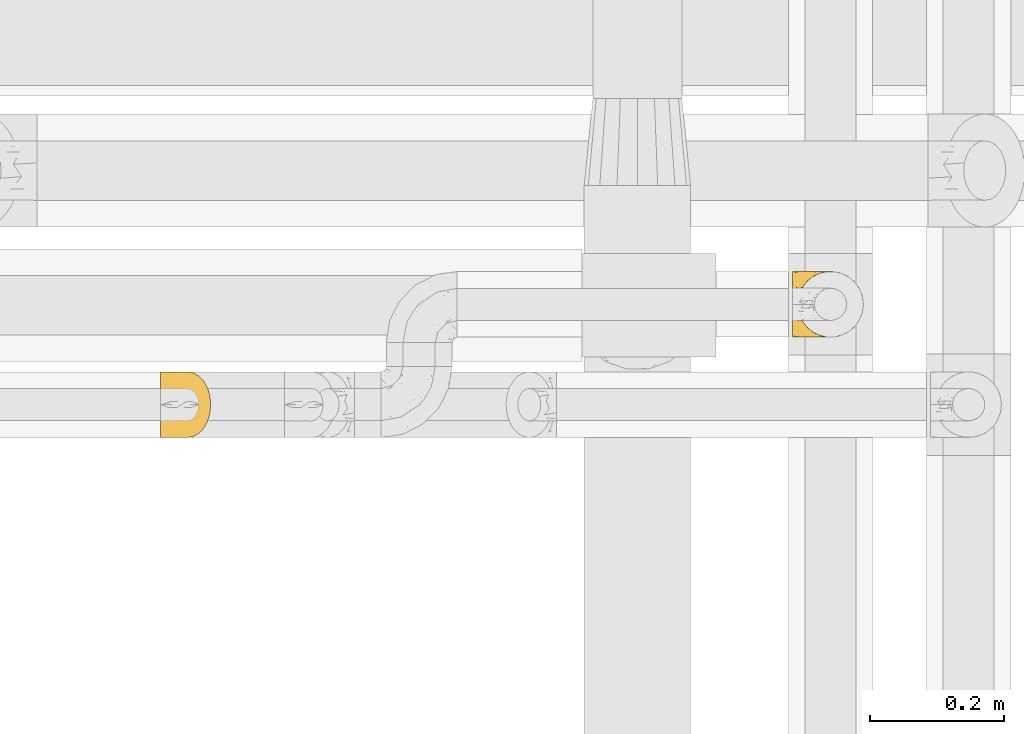
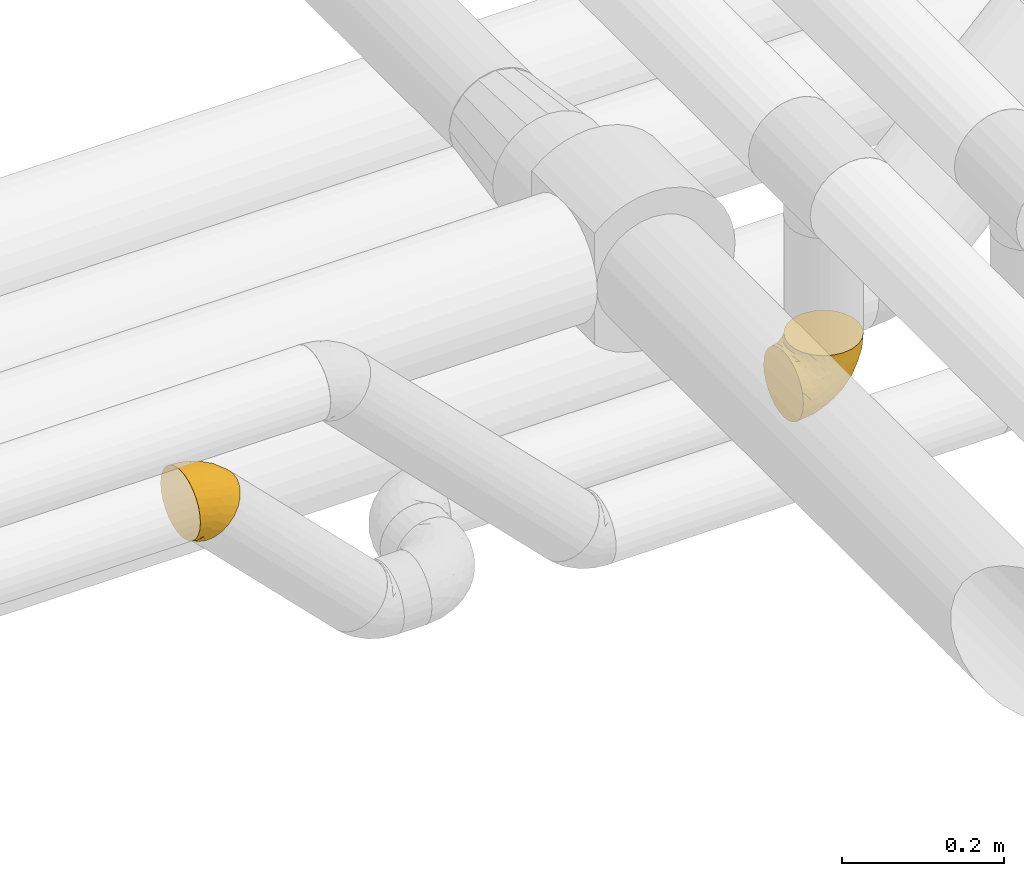
# One storey, part 29 of 93: 2 coverings.
"""IFC2X3 building model written with IfcOpenShell, lengths in millimetres."""

from ifc_helpers import new_model, entity, si_unit, converted_unit, derived_unit, direction, frame, origin, place, context, subcontext, project, spatial, faceted_brep, element, save


model = new_model("IFC2X3")

# Units and contexts
model_context = context("Model", 3, precision=0.01, world=origin(), true_north=direction((6.12303176911189e-17, 1.0)))
body_context = subcontext(model_context, "Body", "Model", "MODEL_VIEW")
ifc_project = project(units=[si_unit("LENGTHUNIT", "METRE", prefix="MILLI"), si_unit("AREAUNIT", "SQUARE_METRE"), si_unit("VOLUMEUNIT", "CUBIC_METRE"), converted_unit("PLANEANGLEUNIT", "DEGREE", entity("IfcRatioMeasure", 0.0174532925199433), si_unit("PLANEANGLEUNIT", "RADIAN"), dimensions=[0, 0, 0, 0, 0, 0, 0]), si_unit("MASSUNIT", "GRAM", prefix="KILO"), derived_unit("MASSDENSITYUNIT", [(si_unit("MASSUNIT", "GRAM", prefix="KILO"), 1), (si_unit("LENGTHUNIT", "METRE"), -3)]), derived_unit("MOMENTOFINERTIAUNIT", [(si_unit("LENGTHUNIT", "METRE"), 4)]), si_unit("TIMEUNIT", "SECOND"), si_unit("FREQUENCYUNIT", "HERTZ"), si_unit("THERMODYNAMICTEMPERATUREUNIT", "DEGREE_CELSIUS"), derived_unit("THERMALTRANSMITTANCEUNIT", [(si_unit("MASSUNIT", "GRAM", prefix="KILO"), 1), (si_unit("THERMODYNAMICTEMPERATUREUNIT", "KELVIN"), -1), (si_unit("TIMEUNIT", "SECOND"), -3)]), derived_unit("VOLUMETRICFLOWRATEUNIT", [(si_unit("LENGTHUNIT", "METRE"), 3), (si_unit("TIMEUNIT", "SECOND"), -1)]), derived_unit("MASSFLOWRATEUNIT", [(si_unit("MASSUNIT", "GRAM", prefix="KILO"), 1), (si_unit("TIMEUNIT", "SECOND"), -1)]), derived_unit("ROTATIONALFREQUENCYUNIT", [(si_unit("TIMEUNIT", "SECOND"), -1)]), si_unit("ELECTRICCURRENTUNIT", "AMPERE"), si_unit("ELECTRICVOLTAGEUNIT", "VOLT"), si_unit("POWERUNIT", "WATT"), si_unit("FORCEUNIT", "NEWTON", prefix="KILO"), si_unit("ILLUMINANCEUNIT", "LUX"), si_unit("LUMINOUSFLUXUNIT", "LUMEN"), si_unit("LUMINOUSINTENSITYUNIT", "CANDELA"), derived_unit("USERDEFINED", [(si_unit("MASSUNIT", "GRAM", prefix="KILO"), -1), (si_unit("LENGTHUNIT", "METRE"), -2), (si_unit("TIMEUNIT", "SECOND"), 3), (si_unit("LUMINOUSFLUXUNIT", "LUMEN"), 1)]), derived_unit("LINEARVELOCITYUNIT", [(si_unit("LENGTHUNIT", "METRE"), 1), (si_unit("TIMEUNIT", "SECOND"), -1)]), si_unit("PRESSUREUNIT", "PASCAL"), derived_unit("USERDEFINED", [(si_unit("LENGTHUNIT", "METRE"), -2), (si_unit("MASSUNIT", "GRAM", prefix="KILO"), 1), (si_unit("TIMEUNIT", "SECOND"), -2)]), derived_unit("LINEARFORCEUNIT", [(si_unit("MASSUNIT", "GRAM", prefix="KILO"), 1), (si_unit("LENGTHUNIT", "METRE"), 1), (si_unit("TIMEUNIT", "SECOND"), -2), (si_unit("LENGTHUNIT", "METRE"), -1)]), derived_unit("PLANARFORCEUNIT", [(si_unit("MASSUNIT", "GRAM", prefix="KILO"), 1), (si_unit("LENGTHUNIT", "METRE"), 1), (si_unit("TIMEUNIT", "SECOND"), -2), (si_unit("LENGTHUNIT", "METRE"), -2)])], contexts=[model_context])

# Site, building, storey
site_placement = place(None, origin())
site = spatial("IfcSite", under=ifc_project, at=site_placement, CompositionType="ELEMENT")
building_placement = place(site_placement, origin())
building = spatial("IfcBuilding", under=site, at=building_placement, CompositionType="ELEMENT")
storey_placement = place(building_placement, frame((0.0, 0.0, -4200.0)))
storey = spatial("IfcBuildingStorey", under=building, at=storey_placement, CompositionType="ELEMENT", Elevation=-4200.0)

# Coverings
covering_1_placement = place(storey_placement, frame((23465.0, 8660.4, 2889.8)))
element("IfcCovering", 1, at=covering_1_placement, inside=storey, Name=":ADSK_", ObjectType=":ADSK_", PredefinedType="INSULATION", context=body_context, shape_type="Brep", body=[
    faceted_brep([(1.6, 39.8, 5.13), (1.6, 29.41, 8.77), (1.6, 20.09, 14.62), (1.6, 12.31, 22.41), (1.6, 6.46, 31.73), (1.6, 2.83, 42.11), (1.6, 1.6, 53.04), (1.6, 2.83, 63.99), (1.6, 6.47, 74.38), (1.6, 12.32, 83.7), (1.6, 20.11, 91.48), (1.6, 29.43, 97.33), (1.6, 39.81, 100.96), (1.6, 50.75, 102.19), (1.6, 61.69, 100.96), (1.6, 72.08, 97.32), (1.6, 81.4, 91.47), (1.6, 89.18, 83.68), (1.6, 95.03, 74.36), (1.6, 98.66, 63.98), (1.6, 99.9, 53.04), (1.6, 98.66, 42.1), (1.6, 95.02, 31.71), (1.6, 89.17, 22.39), (1.6, 81.38, 14.61), (1.6, 72.06, 8.76), (1.6, 61.68, 5.13), (1.6, 50.75, 3.89), (8.33, 63.47, 2.78), (11.8, 75.32, 6.25), (17.33, 85.5, 11.77), (24.52, 93.31, 18.97), (32.91, 98.22, 27.35), (35.62, 98.73, 30.07), (41.9, 99.9, 36.35), (50.9, 98.22, 45.34), (59.28, 93.31, 53.73), (66.48, 85.5, 60.92), (72.0, 75.32, 66.45), (75.47, 63.47, 69.92), (76.65, 50.75, 71.1), (75.47, 38.02, 69.92), (72.0, 26.17, 66.45), (66.48, 15.99, 60.92), (59.28, 8.18, 53.73), (50.9, 3.27, 45.34), (41.9, 1.6, 36.35), (35.62, 2.76, 30.07), (32.91, 3.27, 27.35), (28.71, 5.73, 23.16), (24.52, 8.18, 18.97), (17.33, 15.99, 11.77), (11.8, 26.17, 6.25), (8.33, 38.02, 2.78), (7.15, 50.75, 1.6), (22.47, 17.06, 86.45), (54.67, 50.75, 87.97), (62.68, 42.16, 81.93), (55.4, 21.74, 76.36), (58.06, 32.73, 81.87), (39.2, 26.38, 88.36), (50.71, 13.88, 70.88), (43.39, 40.98, 92.55), (33.67, 10.72, 75.33), (40.0, 18.26, 81.72), (22.29, 5.11, 68.4), (42.19, 6.1, 62.14), (32.54, 2.75, 56.16), (16.07, 2.16, 58.8), (23.41, 1.6, 48.71), (19.48, 25.58, 93.64), (24.45, 35.33, 97.16), (29.07, 50.75, 98.58), (16.3, 9.83, 78.98), (28.06, 1.6, 45.6), (32.71, 1.6, 42.49), (35.01, 1.6, 40.95), (37.31, 1.6, 39.42), (7.01, 1.6, 51.97), (12.43, 1.6, 50.89), (17.92, 1.6, 49.8), (5.82, 31.89, 6.86), (19.85, 3.63, 35.0), (26.57, 3.42, 31.94), (16.36, 2.64, 40.6), (14.25, 5.35, 32.05), (8.46, 19.98, 13.41), (14.01, 14.31, 16.6), (12.95, 9.44, 24.2), (30.54, 2.88, 31.56), (6.92, 2.5, 43.37), (11.71, 2.44, 42.87), (5.12, 41.56, 4.01), (19.42, 8.24, 23.01), (6.71, 12.78, 21.32), (9.96, 5.31, 33.36), (4.6, 50.75, 3.3), (14.01, 87.18, 16.6), (8.45, 81.5, 13.4), (19.42, 93.25, 23.01), (5.12, 59.93, 4.01), (5.82, 69.59, 6.85), (7.01, 99.9, 51.97), (12.94, 92.03, 24.17), (37.31, 99.9, 39.42), (31.44, 99.1, 33.9), (6.71, 88.7, 21.3), (26.57, 98.07, 31.94), (23.41, 99.9, 48.71), (19.84, 97.86, 34.99), (16.36, 98.85, 40.59), (28.06, 99.9, 45.6), (9.96, 96.17, 33.34), (12.43, 99.9, 50.89), (6.93, 98.99, 43.38), (11.7, 99.04, 42.85), (14.25, 96.14, 32.03), (17.92, 99.9, 49.8), (32.71, 99.9, 42.49), (22.29, 96.38, 68.39), (32.54, 98.74, 56.15), (22.47, 84.45, 86.44), (42.19, 95.4, 62.12), (33.66, 90.78, 75.32), (55.02, 60.07, 86.73), (58.05, 68.76, 81.87), (55.41, 79.75, 76.36), (39.2, 75.13, 88.35), (16.07, 99.34, 58.8), (50.71, 87.61, 70.88), (16.3, 91.67, 78.97), (42.49, 65.98, 91.37), (24.46, 66.17, 97.16), (19.48, 75.92, 93.63), (40.0, 83.22, 81.72)], [[[0, 1, 2, 3, 4, 5, 6, 7, 8, 9, 10, 11, 12, 13, 14, 15, 16, 17, 18, 19, 20, 21, 22, 23, 24, 25, 26, 27]], [[28, 29, 30, 31, 32, 33, 34, 35, 36, 37, 38, 39, 40, 41, 42, 43, 44, 45, 46, 47, 48, 49, 50, 51, 52, 53, 54]], [[9, 55, 10]], [[40, 56, 57]], [[42, 58, 43]], [[59, 60, 58]], [[61, 44, 43]], [[60, 59, 62]], [[63, 61, 64]], [[63, 65, 66]], [[67, 46, 45]], [[66, 67, 45]], [[42, 41, 59]], [[67, 68, 69]], [[58, 61, 43]], [[70, 60, 71]], [[71, 62, 72]], [[72, 12, 71]], [[55, 70, 10]], [[11, 70, 71]], [[59, 58, 42]], [[13, 12, 72]], [[73, 55, 9]], [[67, 69, 74, 75, 76, 77, 46]], [[41, 57, 59]], [[68, 6, 78, 79, 80, 69]], [[8, 7, 65]], [[73, 65, 63]], [[45, 44, 66]], [[67, 66, 65]], [[8, 73, 9]], [[57, 62, 59]], [[68, 65, 7]], [[11, 71, 12]], [[60, 55, 64]], [[66, 44, 61]], [[64, 61, 58]], [[61, 63, 66]], [[60, 64, 58]], [[63, 64, 55]], [[65, 73, 8]], [[55, 73, 63]], [[65, 68, 67]], [[6, 68, 7]], [[10, 70, 11]], [[55, 60, 70]], [[40, 57, 41]], [[62, 57, 56]], [[72, 62, 56]], [[62, 71, 60]], [[52, 81, 53]], [[82, 83, 74]], [[84, 85, 82]], [[86, 87, 88]], [[77, 89, 48]], [[87, 52, 51]], [[90, 4, 91]], [[92, 0, 27]], [[86, 1, 81]], [[54, 53, 92]], [[52, 86, 81]], [[93, 51, 50]], [[87, 51, 93]], [[83, 93, 50]], [[94, 95, 3]], [[4, 3, 95]], [[4, 95, 91]], [[6, 5, 78]], [[94, 88, 85]], [[86, 94, 2]], [[48, 47, 46, 77]], [[96, 92, 27]], [[80, 91, 84]], [[1, 0, 81]], [[2, 1, 86]], [[90, 78, 5]], [[0, 92, 81]], [[94, 86, 88]], [[82, 93, 83]], [[2, 94, 3]], [[80, 84, 69]], [[82, 88, 93]], [[49, 48, 89]], [[69, 82, 74]], [[83, 75, 74]], [[88, 87, 93]], [[52, 87, 86]], [[91, 80, 79]], [[91, 79, 90]], [[84, 91, 95]], [[85, 84, 95]], [[69, 84, 82]], [[78, 90, 79]], [[4, 90, 5]], [[94, 85, 95]], [[82, 85, 88]], [[54, 92, 96]], [[81, 92, 53]], [[83, 89, 75]], [[77, 76, 75, 89]], [[83, 49, 89]], [[83, 50, 49]], [[97, 29, 98]], [[30, 99, 31]], [[100, 101, 28]], [[21, 20, 102]], [[103, 99, 97]], [[101, 29, 28]], [[104, 33, 105]], [[98, 106, 103]], [[107, 31, 99]], [[97, 99, 30]], [[108, 109, 110]], [[25, 98, 101]], [[54, 96, 100]], [[109, 111, 107]], [[27, 26, 100]], [[112, 106, 23]], [[101, 26, 25]], [[102, 113, 114]], [[105, 31, 107]], [[24, 98, 25]], [[23, 106, 24]], [[112, 23, 22]], [[106, 98, 24]], [[22, 21, 114]], [[112, 115, 110]], [[113, 115, 114]], [[29, 101, 98]], [[112, 116, 106]], [[29, 97, 30]], [[96, 27, 100]], [[115, 113, 117]], [[103, 109, 99]], [[109, 107, 99]], [[105, 107, 118]], [[111, 109, 108]], [[111, 118, 107]], [[103, 97, 98]], [[110, 116, 112]], [[110, 115, 117]], [[22, 115, 112]], [[108, 110, 117]], [[116, 109, 103]], [[22, 114, 115]], [[102, 114, 21]], [[109, 116, 110]], [[106, 116, 103]], [[104, 34, 33]], [[33, 32, 105]], [[101, 100, 26]], [[54, 100, 28]], [[104, 105, 118]], [[31, 105, 32]], [[19, 18, 119]], [[35, 34, 120]], [[120, 34, 104, 118, 111, 108]], [[121, 17, 16]], [[36, 35, 122]], [[122, 119, 123]], [[39, 124, 40]], [[125, 126, 127]], [[125, 39, 38]], [[128, 120, 108]], [[129, 36, 122]], [[38, 126, 125]], [[129, 126, 37]], [[37, 126, 38]], [[120, 128, 119]], [[35, 120, 122]], [[119, 18, 130]], [[131, 127, 132]], [[130, 18, 17]], [[133, 16, 15]], [[134, 127, 126]], [[123, 130, 121]], [[125, 127, 131]], [[15, 132, 133]], [[14, 13, 72]], [[72, 56, 124]], [[14, 72, 132]], [[133, 132, 127]], [[123, 129, 122]], [[14, 132, 15]], [[119, 122, 120]], [[128, 20, 19]], [[39, 125, 124]], [[126, 129, 134]], [[36, 129, 37]], [[134, 123, 121]], [[123, 134, 129]], [[127, 134, 121]], [[121, 130, 17]], [[119, 130, 123]], [[128, 108, 117, 113, 102, 20]], [[119, 128, 19]], [[127, 121, 133]], [[16, 133, 121]], [[72, 131, 132]], [[124, 125, 131]], [[72, 124, 131]], [[124, 56, 40]]]),
])
covering_2_placement = place(storey_placement, frame((24409.45, 8810.4, 2649.25)))
element("IfcCovering", 2, at=covering_2_placement, inside=storey, Name=":ADSK_", ObjectType=":ADSK_", PredefinedType="INSULATION", context=body_context, shape_type="Brep", body=[
    faceted_brep([(1.6, 99.9, 50.75), (1.6, 98.66, 39.8), (1.6, 95.02, 29.41), (1.6, 89.17, 20.09), (1.6, 81.38, 12.31), (1.6, 72.06, 6.46), (1.6, 61.68, 2.83), (1.6, 50.75, 1.6), (1.6, 39.8, 2.83), (1.6, 29.41, 6.47), (1.6, 20.09, 12.32), (1.6, 12.31, 20.11), (1.6, 6.46, 29.43), (1.6, 2.83, 39.81), (1.6, 1.6, 50.75), (1.6, 2.24, 56.45), (1.6, 2.83, 61.69), (1.6, 4.65, 66.88), (1.6, 6.47, 72.08), (1.6, 12.32, 81.4), (1.6, 20.11, 89.18), (1.6, 29.43, 95.03), (1.6, 39.81, 98.66), (1.6, 50.75, 99.9), (1.6, 61.69, 98.66), (1.6, 72.08, 95.02), (1.6, 81.4, 89.17), (1.6, 89.18, 81.38), (1.6, 95.03, 72.06), (1.6, 96.85, 66.87), (1.6, 98.66, 61.68), (1.6, 99.25, 56.45), (1.6, 99.57, 53.6), (11.12, 38.02, 107.75), (16.03, 26.17, 107.75), (19.94, 21.08, 107.75), (23.84, 15.99, 107.75), (28.93, 12.09, 107.75), (34.02, 8.18, 107.75), (39.95, 5.73, 107.75), (45.87, 3.27, 107.75), (52.86, 2.35, 107.75), (55.73, 1.97, 107.75), (58.6, 1.6, 107.75), (71.32, 3.27, 107.75), (83.17, 8.18, 107.75), (93.35, 15.99, 107.75), (101.16, 26.17, 107.75), (106.07, 38.02, 107.75), (107.75, 50.75, 107.75), (106.07, 63.47, 107.75), (101.16, 75.32, 107.75), (93.35, 85.5, 107.75), (83.17, 93.31, 107.75), (71.32, 98.22, 107.75), (58.6, 99.9, 107.75), (52.86, 99.14, 107.75), (45.87, 98.22, 107.75), (39.95, 95.77, 107.75), (34.02, 93.31, 107.75), (28.93, 89.4, 107.75), (23.84, 85.5, 107.75), (19.94, 80.41, 107.75), (16.03, 75.32, 107.75), (11.12, 63.47, 107.75), (9.45, 50.75, 107.75), (81.82, 59.31, 39.38), (84.02, 73.08, 49.75), (93.05, 63.72, 57.38), (102.55, 50.75, 74.94), (104.83, 58.64, 85.97), (105.83, 50.75, 95.66), (91.87, 76.74, 67.82), (101.74, 67.68, 83.09), (97.07, 78.92, 89.16), (38.45, 94.31, 37.01), (22.17, 98.76, 43.46), (42.04, 98.4, 51.79), (77.69, 94.57, 85.58), (75.76, 89.91, 62.84), (62.11, 96.32, 62.77), (66.08, 98.79, 88.17), (54.26, 99.9, 85.93), (55.35, 99.9, 91.42), (56.44, 99.9, 96.91), (56.98, 99.9, 99.62), (57.52, 99.9, 102.33), (87.84, 87.31, 82.57), (19.41, 95.61, 32.75), (48.89, 60.43, 13.79), (26.34, 65.24, 6.77), (44.55, 72.87, 16.46), (23.41, 99.9, 55.08), (28.03, 99.9, 58.17), (32.65, 99.9, 61.26), (37.28, 99.9, 64.35), (41.9, 99.9, 67.44), (20.6, 90.65, 24.18), (63.36, 63.14, 23.37), (62.21, 91.89, 49.76), (19.94, 75.25, 9.84), (13.68, 50.75, 3.51), (80.85, 82.18, 55.75), (66.53, 85.08, 42.34), (71.06, 76.93, 37.78), (63.99, 50.75, 21.87), (75.73, 50.75, 33.61), (26.77, 83.02, 17.1), (4.31, 99.9, 51.28), (7.01, 99.9, 51.82), (12.43, 99.9, 52.9), (17.92, 99.9, 53.99), (43.43, 87.13, 28.01), (56.23, 80.85, 28.99), (54.97, 99.17, 69.9), (34.4, 50.75, 6.79), (44.99, 99.9, 72.06), (48.08, 99.9, 76.69), (51.17, 99.9, 81.31), (87.47, 50.75, 45.35), (74.55, 67.61, 34.79), (60.86, 72.25, 25.72), (49.19, 50.75, 14.33), (95.01, 50.75, 60.15), (10.27, 98.69, 62.38), (48.79, 99.01, 100.57), (45.16, 98.79, 91.06), (44.99, 98.29, 97.66), (6.17, 68.51, 97.55), (7.65, 76.82, 93.65), (21.59, 98.54, 66.85), (19.96, 99.3, 61.93), (21.0, 83.57, 101.4), (27.2, 89.47, 100.07), (14.83, 75.76, 101.36), (19.7, 84.86, 95.94), (10.93, 75.89, 96.3), (9.63, 64.77, 101.98), (19.97, 90.83, 85.88), (21.13, 94.62, 78.88), (14.14, 90.37, 82.8), (30.2, 91.18, 102.58), (36.65, 95.55, 96.59), (8.12, 88.65, 82.88), (9.93, 84.11, 88.57), (24.62, 91.75, 88.67), (11.87, 96.86, 69.08), (7.15, 50.75, 102.19), (5.32, 58.97, 100.06), (26.68, 98.37, 70.56), (13.92, 83.91, 91.07), (30.67, 97.52, 77.56), (42.89, 98.76, 86.38), (34.04, 95.26, 91.79), (36.6, 98.04, 81.71), (26.41, 90.65, 94.11), (10.07, 93.51, 76.09), (15.83, 94.16, 76.91), (41.99, 99.1, 81.44), (14.83, 25.73, 101.37), (26.4, 10.84, 94.12), (21.01, 17.92, 101.41), (19.71, 16.64, 95.96), (5.72, 30.44, 96.22), (21.6, 2.95, 66.85), (19.96, 2.19, 61.94), (28.03, 1.6, 58.17), (11.87, 4.63, 69.1), (9.93, 17.39, 88.58), (58.06, 1.6, 105.04), (56.44, 1.6, 96.91), (57.52, 1.6, 102.33), (8.13, 12.86, 82.9), (14.15, 11.13, 82.82), (44.99, 3.2, 97.66), (36.65, 5.94, 96.59), (30.2, 10.31, 102.58), (10.06, 8.0, 76.13), (15.83, 7.34, 76.93), (48.79, 2.48, 100.57), (42.89, 2.73, 86.38), (45.38, 2.64, 90.86), (12.43, 1.6, 52.9), (10.28, 2.8, 62.39), (9.64, 36.71, 101.98), (55.35, 1.6, 91.42), (54.26, 1.6, 85.93), (6.05, 38.59, 99.49), (7.01, 1.6, 51.82), (9.72, 1.6, 52.36), (32.65, 1.6, 61.26), (26.68, 3.12, 70.56), (13.92, 17.59, 91.09), (37.28, 1.6, 64.35), (30.66, 3.98, 77.6), (21.14, 6.87, 78.89), (36.59, 3.45, 81.71), (24.6, 9.76, 88.69), (17.92, 1.6, 53.99), (23.41, 1.6, 55.08), (10.93, 25.62, 96.31), (19.97, 10.67, 85.9), (41.99, 2.39, 81.45), (48.08, 1.6, 76.69), (34.04, 6.23, 91.79), (27.21, 12.02, 100.07), (51.17, 1.6, 81.31), (44.99, 1.6, 72.06), (41.9, 1.6, 67.44), (55.26, 2.4, 69.6), (104.83, 42.85, 85.97), (87.84, 14.18, 82.57), (75.91, 11.56, 63.16), (80.84, 19.27, 55.81), (91.87, 24.75, 67.81), (83.98, 28.37, 49.73), (19.16, 5.95, 32.55), (22.37, 2.79, 43.23), (66.08, 2.71, 88.17), (93.05, 37.78, 57.38), (101.74, 33.81, 83.08), (97.07, 22.57, 89.16), (77.69, 6.92, 85.58), (44.55, 28.61, 16.46), (26.34, 36.24, 6.77), (48.9, 41.05, 13.8), (70.99, 24.55, 37.71), (74.55, 33.88, 34.8), (37.8, 7.11, 36.83), (81.82, 42.18, 39.38), (26.77, 18.46, 17.12), (20.6, 10.84, 24.19), (56.15, 20.69, 28.89), (60.85, 29.27, 25.69), (42.06, 3.1, 51.77), (57.03, 9.18, 45.66), (63.4, 38.38, 23.39), (19.94, 26.23, 9.85), (43.59, 14.34, 28.11), (62.61, 5.46, 62.27), (66.52, 16.39, 42.35)], [[[0, 1, 2, 3, 4, 5, 6, 7, 8, 9, 10, 11, 12, 13, 14, 15, 16, 17, 18, 19, 20, 21, 22, 23, 24, 25, 26, 27, 28, 29, 30, 31, 32]], [[33, 34, 35, 36, 37, 38, 39, 40, 41, 42, 43, 44, 45, 46, 47, 48, 49, 50, 51, 52, 53, 54, 55, 56, 57, 58, 59, 60, 61, 62, 63, 64, 65]], [[66, 67, 68]], [[69, 70, 71]], [[68, 72, 73]], [[73, 72, 74]], [[75, 76, 77]], [[78, 79, 80]], [[51, 50, 73]], [[81, 82, 83, 84, 85, 86, 55]], [[52, 87, 53]], [[74, 52, 51]], [[2, 1, 88]], [[89, 90, 91]], [[77, 92, 93, 94, 95, 96]], [[55, 54, 81]], [[78, 53, 87]], [[5, 90, 6]], [[88, 76, 75]], [[97, 3, 2]], [[89, 91, 98]], [[99, 80, 79]], [[90, 5, 100]], [[74, 87, 52]], [[100, 5, 4]], [[90, 101, 6]], [[79, 102, 103]], [[102, 67, 104]], [[105, 98, 106]], [[107, 4, 3]], [[76, 0, 108, 109, 110, 111, 92]], [[107, 112, 113]], [[114, 77, 96]], [[89, 115, 90]], [[114, 96, 116, 117, 118, 82]], [[75, 97, 88]], [[119, 66, 68]], [[50, 71, 70]], [[100, 91, 90]], [[99, 77, 80]], [[102, 104, 103]], [[97, 107, 3]], [[80, 81, 78]], [[107, 97, 112]], [[68, 73, 70]], [[66, 98, 120]], [[78, 81, 54]], [[114, 81, 80]], [[53, 78, 54]], [[78, 87, 79]], [[102, 87, 72]], [[79, 103, 99]], [[4, 107, 100]], [[91, 100, 107]], [[88, 97, 2]], [[112, 97, 75]], [[99, 112, 75]], [[103, 104, 113]], [[91, 121, 98]], [[89, 105, 122, 115]], [[101, 90, 115]], [[101, 7, 6]], [[88, 1, 76]], [[0, 76, 1]], [[92, 77, 76]], [[73, 74, 51]], [[87, 74, 72]], [[81, 114, 82]], [[77, 114, 80]], [[87, 102, 79]], [[67, 102, 72]], [[68, 67, 72]], [[67, 120, 104]], [[120, 121, 104]], [[104, 121, 113]], [[121, 120, 98]], [[91, 107, 113]], [[91, 113, 121]], [[103, 113, 112]], [[106, 98, 66]], [[105, 89, 98]], [[106, 66, 119]], [[67, 66, 120]], [[68, 69, 123, 119]], [[50, 49, 71]], [[50, 70, 73]], [[112, 99, 103]], [[77, 99, 75]], [[69, 68, 70]], [[29, 124, 110]], [[84, 83, 125]], [[126, 82, 118]], [[59, 58, 127]], [[25, 128, 129]], [[130, 93, 131]], [[132, 62, 133]], [[134, 135, 136]], [[137, 65, 64]], [[64, 134, 137]], [[138, 139, 140]], [[111, 110, 124, 92]], [[134, 136, 137]], [[134, 64, 63]], [[141, 60, 142]], [[125, 58, 57]], [[143, 144, 140]], [[143, 26, 144]], [[127, 83, 82]], [[28, 124, 29]], [[32, 31, 30, 110, 109, 108, 0]], [[30, 29, 110]], [[135, 145, 138]], [[28, 146, 124]], [[57, 56, 55, 86, 85, 84]], [[147, 148, 23]], [[24, 23, 148]], [[25, 144, 26]], [[95, 94, 149]], [[24, 128, 25]], [[150, 138, 144]], [[124, 146, 131]], [[127, 58, 125]], [[151, 149, 139]], [[127, 126, 142]], [[142, 59, 127]], [[152, 142, 126]], [[153, 154, 155]], [[153, 133, 141]], [[146, 28, 27]], [[143, 156, 27]], [[157, 149, 130]], [[61, 133, 62]], [[134, 132, 135]], [[148, 128, 24]], [[65, 137, 147]], [[147, 137, 148]], [[128, 137, 136]], [[137, 128, 148]], [[128, 136, 129]], [[150, 129, 136]], [[25, 129, 144]], [[158, 152, 117]], [[152, 118, 117]], [[153, 142, 152]], [[158, 116, 154]], [[145, 151, 138]], [[153, 152, 158]], [[133, 153, 155]], [[133, 155, 132]], [[153, 141, 142]], [[135, 132, 155]], [[134, 63, 132]], [[145, 135, 155]], [[135, 138, 150]], [[155, 154, 145]], [[151, 154, 96]], [[154, 151, 145]], [[149, 94, 130]], [[82, 126, 127]], [[118, 152, 126]], [[151, 96, 95]], [[139, 149, 157]], [[151, 95, 149]], [[93, 92, 131]], [[130, 146, 156]], [[130, 94, 93]], [[84, 125, 57]], [[127, 125, 83]], [[140, 139, 157]], [[151, 139, 138]], [[140, 157, 143]], [[138, 140, 144]], [[156, 143, 157]], [[27, 26, 143]], [[130, 156, 157]], [[146, 27, 156]], [[132, 63, 62]], [[124, 131, 92]], [[130, 131, 146]], [[129, 150, 144]], [[135, 150, 136]], [[60, 141, 61]], [[60, 59, 142]], [[133, 61, 141]], [[116, 96, 154]], [[153, 158, 154]], [[158, 117, 116]], [[34, 33, 159]], [[160, 161, 162]], [[22, 21, 163]], [[164, 165, 166]], [[19, 18, 167]], [[168, 21, 20]], [[169, 43, 42, 41, 40, 170, 171]], [[172, 173, 168]], [[174, 38, 175]], [[37, 36, 176]], [[177, 164, 178]], [[40, 179, 170]], [[180, 181, 175]], [[17, 182, 183]], [[65, 147, 184]], [[185, 174, 186]], [[23, 22, 187]], [[174, 39, 38]], [[15, 14, 188, 189, 182, 16]], [[179, 40, 39]], [[190, 191, 164]], [[192, 163, 168]], [[33, 184, 159]], [[178, 173, 172]], [[193, 194, 191]], [[18, 183, 167]], [[173, 178, 195]], [[196, 197, 194]], [[198, 199, 183, 182]], [[182, 17, 16]], [[18, 17, 183]], [[200, 159, 184]], [[192, 168, 201]], [[187, 163, 200]], [[202, 203, 180]], [[185, 179, 174]], [[160, 204, 205]], [[206, 181, 180]], [[206, 180, 203]], [[199, 165, 183]], [[165, 164, 167]], [[172, 177, 178]], [[200, 192, 162]], [[205, 161, 160]], [[65, 184, 33]], [[163, 187, 22]], [[175, 204, 180]], [[174, 181, 186]], [[204, 196, 202]], [[197, 160, 162]], [[196, 207, 202]], [[37, 176, 175]], [[196, 204, 160]], [[176, 204, 175]], [[205, 35, 161]], [[34, 159, 161]], [[162, 161, 159]], [[200, 162, 159]], [[197, 162, 201]], [[194, 197, 201]], [[196, 160, 197]], [[191, 195, 178]], [[208, 196, 194]], [[186, 181, 206]], [[175, 181, 174]], [[191, 190, 193]], [[193, 208, 194]], [[195, 194, 201]], [[178, 164, 191]], [[168, 163, 21]], [[166, 165, 199]], [[166, 190, 164]], [[187, 200, 184]], [[184, 147, 187]], [[23, 187, 147]], [[174, 179, 39]], [[170, 179, 185]], [[194, 195, 191]], [[173, 201, 168]], [[201, 173, 195]], [[172, 168, 20]], [[20, 19, 172]], [[177, 172, 19]], [[19, 167, 177]], [[164, 177, 167]], [[35, 205, 36]], [[35, 34, 161]], [[183, 165, 167]], [[162, 192, 201]], [[163, 192, 200]], [[175, 38, 37]], [[36, 205, 176]], [[204, 176, 205]], [[204, 202, 180]], [[207, 196, 208]], [[207, 203, 202]], [[209, 186, 206, 203, 207, 208]], [[48, 210, 71]], [[211, 212, 213]], [[214, 213, 215]], [[216, 217, 13]], [[218, 43, 169, 171, 170, 185, 186]], [[219, 220, 214]], [[47, 46, 221]], [[210, 48, 220]], [[211, 222, 212]], [[222, 45, 44]], [[221, 220, 47]], [[47, 220, 48]], [[221, 211, 214]], [[223, 224, 225]], [[211, 46, 45]], [[226, 227, 215]], [[43, 218, 44]], [[217, 216, 228]], [[215, 229, 219]], [[14, 13, 217]], [[224, 9, 8]], [[10, 230, 11]], [[11, 231, 12]], [[232, 223, 233]], [[234, 208, 193, 190, 166, 199]], [[235, 234, 228]], [[222, 44, 218]], [[106, 229, 236]], [[224, 237, 9]], [[231, 238, 228]], [[9, 237, 10]], [[115, 224, 101]], [[239, 234, 235]], [[231, 11, 230]], [[223, 230, 237]], [[224, 8, 101]], [[223, 236, 233]], [[225, 115, 122, 105]], [[216, 12, 231]], [[209, 234, 239]], [[210, 219, 69]], [[219, 214, 215]], [[229, 119, 219]], [[209, 218, 186]], [[239, 212, 222]], [[239, 222, 218]], [[45, 222, 211]], [[235, 212, 239]], [[213, 212, 240]], [[223, 237, 224]], [[230, 10, 237]], [[238, 231, 230]], [[216, 231, 228]], [[232, 230, 223]], [[235, 238, 240]], [[115, 225, 224]], [[233, 236, 227]], [[8, 7, 101]], [[234, 209, 208]], [[218, 209, 239]], [[217, 228, 234]], [[13, 12, 216]], [[234, 199, 217]], [[217, 199, 198, 182, 189, 188, 14]], [[211, 221, 46]], [[220, 221, 214]], [[71, 210, 69]], [[71, 49, 48]], [[219, 210, 220]], [[226, 215, 213]], [[211, 213, 214]], [[226, 213, 240]], [[215, 227, 229]], [[232, 240, 238]], [[233, 227, 226]], [[232, 233, 226]], [[236, 223, 225]], [[240, 232, 226]], [[232, 238, 230]], [[225, 105, 236]], [[236, 105, 106]], [[229, 106, 119]], [[69, 219, 119, 123]], [[236, 229, 227]], [[238, 235, 228]], [[212, 235, 240]]]),
])

save(model, "model.ifc")
